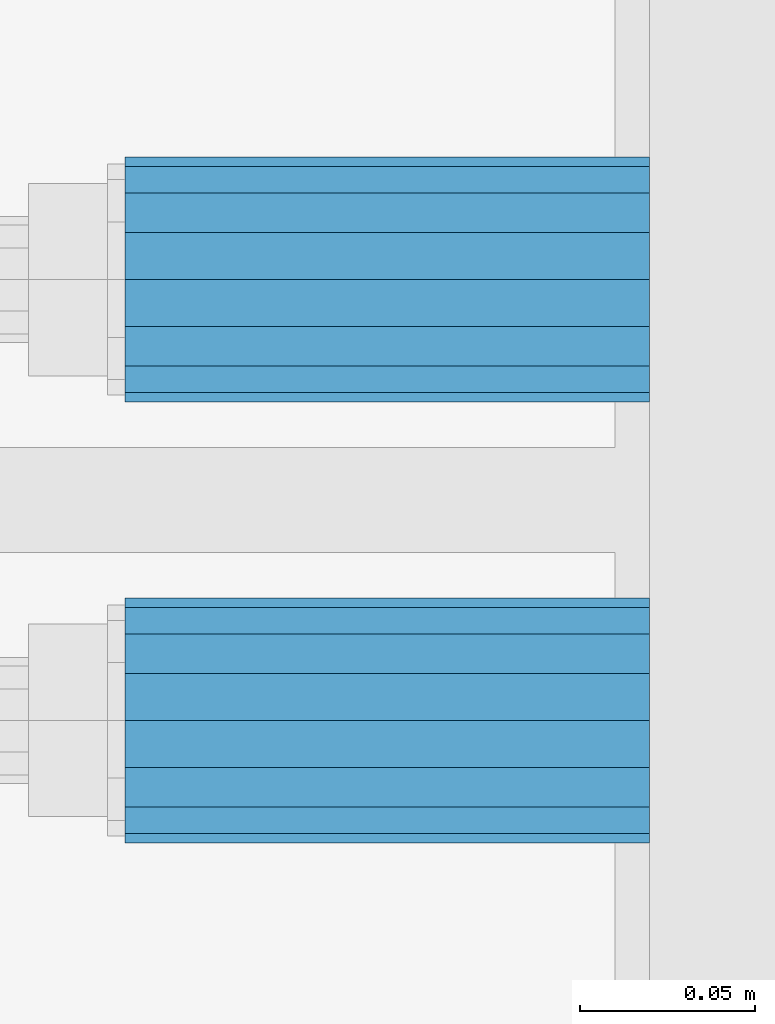
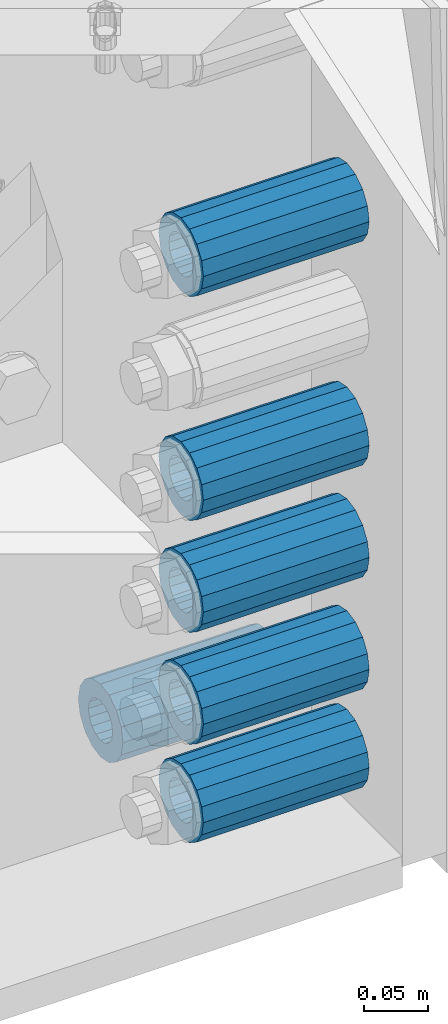
# One storey, part 142 of 240: 6 beams.
"""IFC2X3 building model written with IfcOpenShell, lengths in millimetres."""

from ifc_helpers import new_model, si_unit, frame, origin_with_axes, place, context, subcontext, project, spatial, faceted_brep, material, type_object, element, save


model = new_model("IFC2X3")

# Units and contexts
model_context = context("Model", 3, precision=1e-05, world=origin_with_axes())
body_context = subcontext(model_context, "Body", "Model", "MODEL_VIEW")
ifc_project = project(units=[si_unit("LENGTHUNIT", "METRE", prefix="MILLI"), si_unit("AREAUNIT", "SQUARE_METRE"), si_unit("VOLUMEUNIT", "CUBIC_METRE"), si_unit("MASSUNIT", "GRAM", prefix="KILO"), si_unit("TIMEUNIT", "SECOND"), si_unit("PLANEANGLEUNIT", "RADIAN"), si_unit("SOLIDANGLEUNIT", "STERADIAN"), si_unit("THERMODYNAMICTEMPERATUREUNIT", "DEGREE_CELSIUS"), si_unit("LUMINOUSINTENSITYUNIT", "LUMEN")], contexts=[model_context])

# Site, building, storey
site_placement = place(None, origin_with_axes())
site = spatial("IfcSite", under=ifc_project, at=site_placement, CompositionType="ELEMENT")
building_placement = place(site_placement, origin_with_axes())
building = spatial("IfcBuilding", under=site, at=building_placement, Name="Standard", CompositionType="ELEMENT")
storey_placement = place(building_placement, origin_with_axes())
storey = spatial("IfcBuildingStorey", under=building, at=storey_placement, Name="Undefined", CompositionType="ELEMENT", Elevation=0.0)

# Beams
ifc_material = material()
beam_type = type_object("IfcBeamType", PredefinedType="NOTDEFINED")
beam_1_placement = place(storey_placement, frame((56327.0, 29937.0, -285.0), z_axis=(0.0, 0.0, 1.0), x_axis=(1.0, 0.0, 0.0)))
element("IfcBeam", 1, at=beam_1_placement, inside=storey, type_object=beam_type, material=ifc_material, context=body_context, shape_type="Brep", body=[
    faceted_brep([(-1.31236447487026e-07, -18.9999999995492, -6.26459950581193e-09), (0.0, -17.5537111177146, 7.27098521493673), (150.0, -17.5537111177146, 7.27098521493673), (150.0, -19.0, 0.0), (0.0, -13.4350288425449, 13.4350288425444), (150.0, -13.4350288425449, 13.4350288425444), (0.0, -7.27098521493826, 17.5537111177144), (150.0, -7.27098521493826, 17.5537111177144), (-6.35918695479631e-09, 4.50199877377599e-10, 18.9999999937281), (150.0, 0.0, 19.0), (0.0, 7.27098521493826, 17.5537111177144), (150.0, 7.27098521493826, 17.5537111177144), (0.0, 13.4350288425449, 13.4350288425444), (150.0, 13.4350288425449, 13.4350288425444), (0.0, 17.5537111177146, 7.27098521493673), (150.0, 17.5537111177146, 7.27098521493673), (1.33248249767348e-07, 19.0000000004507, -6.26459950581193e-09), (150.0, 19.0, 0.0), (0.0, 17.5537111177146, -7.27098521493673), (150.0, 17.5537111177146, -7.27098521493673), (0.0, 13.4350288425449, -13.4350288425444), (150.0, 13.4350288425449, -13.4350288425444), (0.0, 7.27098521493826, -17.5537111177144), (150.0, 7.27098521493826, -17.5537111177144), (8.37098923511803e-09, 4.50313564215321e-10, -19.0000000062646), (150.0, 0.0, -19.0), (0.0, -7.27098521493826, -17.5537111177144), (150.0, -7.27098521493826, -17.5537111177144), (0.0, -13.4350288425449, -13.4350288425444), (150.0, -13.4350288425449, -13.4350288425444), (0.0, -17.5537111177146, -7.27098521493673), (150.0, -17.5537111177146, -7.27098521493673), (0.0, -35.0, 0.0), (7.27595761418343e-12, -32.335783637895, -13.3939201327739), (150.0, -32.3357836378964, -13.3939201327782), (150.0, -35.0, 0.0), (0.0, -24.7487373415292, -24.7487373415279), (150.0, -24.7487373415279, -24.7487373415292), (7.27595761418343e-12, -13.3939201327781, -32.3357836378891), (150.0, -13.3939201327776, -32.335783637895), (7.27595761418343e-12, 0.0, -35.0), (150.0, 0.0, -35.0), (7.27595761418343e-12, 13.3939201327782, -32.3357836378891), (150.0, 13.3939201327776, -32.335783637895), (0.0, 24.7487373415292, -24.7487373415279), (150.0, 24.7487373415279, -24.7487373415291), (7.27595761418343e-12, 32.335783637895, -13.3939201327739), (150.0, 32.3357836378964, -13.3939201327781), (0.0, 35.0, 0.0), (150.0, 35.0, 0.0), (0.0, 32.335783637895, 13.3939201327812), (150.0, 32.3357836378964, 13.3939201327781), (0.0, 24.7487373415292, 24.7487373415279), (150.0, 24.7487373415279, 24.7487373415292), (0.0, 13.3939201327781, 32.3357836378964), (150.0, 13.3939201327776, 32.335783637895), (0.0, 0.0, 35.0), (150.0, 0.0, 35.0), (0.0, -13.3939201327781, 32.3357836378964), (150.0, -13.3939201327776, 32.335783637895), (0.0, -24.7487373415292, 24.7487373415279), (150.0, -24.7487373415279, 24.7487373415292), (0.0, -32.335783637895, 13.3939201327812), (150.0, -32.3357836378964, 13.3939201327781)], [[[0, 1, 2, 3]], [[1, 4, 5, 2]], [[4, 6, 7, 5]], [[6, 8, 9, 7]], [[8, 10, 11, 9]], [[10, 12, 13, 11]], [[12, 14, 15, 13]], [[14, 16, 17, 15]], [[16, 18, 19, 17]], [[18, 20, 21, 19]], [[20, 22, 23, 21]], [[22, 24, 25, 23]], [[24, 26, 27, 25]], [[26, 28, 29, 27]], [[28, 30, 31, 29]], [[30, 0, 3, 31]], [[32, 33, 34, 35]], [[33, 36, 37, 34]], [[36, 38, 39, 37]], [[38, 40, 41, 39]], [[40, 42, 43, 41]], [[42, 44, 45, 43]], [[44, 46, 47, 45]], [[46, 48, 49, 47]], [[48, 50, 51, 49]], [[50, 52, 53, 51]], [[52, 54, 55, 53]], [[54, 56, 57, 55]], [[56, 58, 59, 57]], [[58, 60, 61, 59]], [[60, 62, 63, 61]], [[62, 32, 35, 63]], [[37, 39, 41, 43, 45, 47, 49, 51, 53, 55, 57, 59, 61, 63, 35, 34], [5, 7, 9, 11, 13, 15, 17, 19, 21, 23, 25, 27, 29, 31, 3, 2]], [[62, 60, 58, 56, 54, 52, 50, 48, 46, 44, 42, 40, 38, 36, 33, 32], [30, 28, 26, 24, 22, 20, 18, 16, 14, 12, 10, 8, 6, 4, 1, 0]]]),
])
beam_2_placement = place(storey_placement, frame((56327.0, 29937.0, -499.0), z_axis=(0.0, 0.0, 1.0), x_axis=(1.0, 0.0, 0.0)))
element("IfcBeam", 2, at=beam_2_placement, inside=storey, type_object=beam_type, material=ifc_material, context=body_context, shape_type="Brep", body=[
    faceted_brep([(-1.31236447487026e-07, -18.9999999995492, -6.26459950581193e-09), (0.0, -17.5537111177146, 7.27098521493673), (150.0, -17.5537111177146, 7.27098521493673), (150.0, -19.0, 0.0), (0.0, -13.4350288425449, 13.4350288425444), (150.0, -13.4350288425449, 13.4350288425444), (0.0, -7.27098521493826, 17.5537111177144), (150.0, -7.27098521493826, 17.5537111177144), (-6.35918695479631e-09, 4.50199877377599e-10, 18.9999999937281), (150.0, 0.0, 19.0), (0.0, 7.27098521493826, 17.5537111177144), (150.0, 7.27098521493826, 17.5537111177144), (0.0, 13.4350288425449, 13.4350288425444), (150.0, 13.4350288425449, 13.4350288425444), (0.0, 17.5537111177146, 7.27098521493673), (150.0, 17.5537111177146, 7.27098521493673), (1.33248249767348e-07, 19.0000000004507, -6.26459950581193e-09), (150.0, 19.0, 0.0), (0.0, 17.5537111177146, -7.27098521493673), (150.0, 17.5537111177146, -7.27098521493673), (0.0, 13.4350288425449, -13.4350288425444), (150.0, 13.4350288425449, -13.4350288425444), (0.0, 7.27098521493826, -17.5537111177144), (150.0, 7.27098521493826, -17.5537111177144), (8.37098923511803e-09, 4.50313564215321e-10, -19.0000000062646), (150.0, 0.0, -19.0), (0.0, -7.27098521493826, -17.5537111177144), (150.0, -7.27098521493826, -17.5537111177144), (0.0, -13.4350288425449, -13.4350288425444), (150.0, -13.4350288425449, -13.4350288425444), (0.0, -17.5537111177146, -7.27098521493673), (150.0, -17.5537111177146, -7.27098521493673), (0.0, -35.0, 0.0), (7.27595761418343e-12, -32.335783637895, -13.3939201327739), (150.0, -32.3357836378964, -13.3939201327782), (150.0, -35.0, 0.0), (0.0, -24.7487373415292, -24.7487373415279), (150.0, -24.7487373415279, -24.7487373415292), (7.27595761418343e-12, -13.3939201327781, -32.3357836378891), (150.0, -13.3939201327776, -32.335783637895), (7.27595761418343e-12, 0.0, -35.0), (150.0, 0.0, -35.0), (7.27595761418343e-12, 13.3939201327782, -32.3357836378891), (150.0, 13.3939201327776, -32.335783637895), (0.0, 24.7487373415292, -24.7487373415279), (150.0, 24.7487373415279, -24.7487373415291), (7.27595761418343e-12, 32.335783637895, -13.3939201327739), (150.0, 32.3357836378964, -13.3939201327781), (0.0, 35.0, 0.0), (150.0, 35.0, 0.0), (0.0, 32.335783637895, 13.3939201327812), (150.0, 32.3357836378964, 13.3939201327781), (0.0, 24.7487373415292, 24.7487373415279), (150.0, 24.7487373415279, 24.7487373415292), (0.0, 13.3939201327781, 32.3357836378964), (150.0, 13.3939201327776, 32.335783637895), (0.0, 0.0, 35.0), (150.0, 0.0, 35.0), (0.0, -13.3939201327781, 32.3357836378964), (150.0, -13.3939201327776, 32.335783637895), (0.0, -24.7487373415292, 24.7487373415279), (150.0, -24.7487373415279, 24.7487373415292), (0.0, -32.335783637895, 13.3939201327812), (150.0, -32.3357836378964, 13.3939201327781)], [[[0, 1, 2, 3]], [[1, 4, 5, 2]], [[4, 6, 7, 5]], [[6, 8, 9, 7]], [[8, 10, 11, 9]], [[10, 12, 13, 11]], [[12, 14, 15, 13]], [[14, 16, 17, 15]], [[16, 18, 19, 17]], [[18, 20, 21, 19]], [[20, 22, 23, 21]], [[22, 24, 25, 23]], [[24, 26, 27, 25]], [[26, 28, 29, 27]], [[28, 30, 31, 29]], [[30, 0, 3, 31]], [[32, 33, 34, 35]], [[33, 36, 37, 34]], [[36, 38, 39, 37]], [[38, 40, 41, 39]], [[40, 42, 43, 41]], [[42, 44, 45, 43]], [[44, 46, 47, 45]], [[46, 48, 49, 47]], [[48, 50, 51, 49]], [[50, 52, 53, 51]], [[52, 54, 55, 53]], [[54, 56, 57, 55]], [[56, 58, 59, 57]], [[58, 60, 61, 59]], [[60, 62, 63, 61]], [[62, 32, 35, 63]], [[37, 39, 41, 43, 45, 47, 49, 51, 53, 55, 57, 59, 61, 63, 35, 34], [5, 7, 9, 11, 13, 15, 17, 19, 21, 23, 25, 27, 29, 31, 3, 2]], [[62, 60, 58, 56, 54, 52, 50, 48, 46, 44, 42, 40, 38, 36, 33, 32], [30, 28, 26, 24, 22, 20, 18, 16, 14, 12, 10, 8, 6, 4, 1, 0]]]),
])
beam_3_placement = place(storey_placement, frame((56327.0, 29937.0, -606.0), z_axis=(0.0, 0.0, 1.0), x_axis=(1.0, 0.0, 0.0)))
element("IfcBeam", 3, at=beam_3_placement, inside=storey, type_object=beam_type, material=ifc_material, context=body_context, shape_type="Brep", body=[
    faceted_brep([(-1.31236447487026e-07, -18.9999999995492, -6.26459950581193e-09), (0.0, -17.5537111177146, 7.27098521493673), (150.0, -17.5537111177146, 7.27098521493673), (150.0, -19.0, 0.0), (0.0, -13.4350288425449, 13.4350288425444), (150.0, -13.4350288425449, 13.4350288425444), (0.0, -7.27098521493826, 17.5537111177144), (150.0, -7.27098521493826, 17.5537111177144), (-6.35918695479631e-09, 4.50199877377599e-10, 18.9999999937281), (150.0, 0.0, 19.0), (0.0, 7.27098521493826, 17.5537111177144), (150.0, 7.27098521493826, 17.5537111177144), (0.0, 13.4350288425449, 13.4350288425444), (150.0, 13.4350288425449, 13.4350288425444), (0.0, 17.5537111177146, 7.27098521493673), (150.0, 17.5537111177146, 7.27098521493673), (1.33248249767348e-07, 19.0000000004507, -6.26459950581193e-09), (150.0, 19.0, 0.0), (0.0, 17.5537111177146, -7.27098521493673), (150.0, 17.5537111177146, -7.27098521493673), (0.0, 13.4350288425449, -13.4350288425444), (150.0, 13.4350288425449, -13.4350288425444), (0.0, 7.27098521493826, -17.5537111177144), (150.0, 7.27098521493826, -17.5537111177144), (8.37098923511803e-09, 4.50313564215321e-10, -19.0000000062646), (150.0, 0.0, -19.0), (0.0, -7.27098521493826, -17.5537111177144), (150.0, -7.27098521493826, -17.5537111177144), (0.0, -13.4350288425449, -13.4350288425444), (150.0, -13.4350288425449, -13.4350288425444), (0.0, -17.5537111177146, -7.27098521493673), (150.0, -17.5537111177146, -7.27098521493673), (0.0, -35.0, 0.0), (7.27595761418343e-12, -32.335783637895, -13.3939201327739), (150.0, -32.3357836378964, -13.3939201327782), (150.0, -35.0, 0.0), (0.0, -24.7487373415292, -24.7487373415279), (150.0, -24.7487373415279, -24.7487373415292), (7.27595761418343e-12, -13.3939201327781, -32.3357836378891), (150.0, -13.3939201327776, -32.335783637895), (7.27595761418343e-12, 0.0, -35.0), (150.0, 0.0, -35.0), (7.27595761418343e-12, 13.3939201327782, -32.3357836378891), (150.0, 13.3939201327776, -32.335783637895), (0.0, 24.7487373415292, -24.7487373415279), (150.0, 24.7487373415279, -24.7487373415291), (7.27595761418343e-12, 32.335783637895, -13.3939201327739), (150.0, 32.3357836378964, -13.3939201327781), (0.0, 35.0, 0.0), (150.0, 35.0, 0.0), (0.0, 32.335783637895, 13.3939201327812), (150.0, 32.3357836378964, 13.3939201327781), (0.0, 24.7487373415292, 24.7487373415279), (150.0, 24.7487373415279, 24.7487373415292), (0.0, 13.3939201327781, 32.3357836378964), (150.0, 13.3939201327776, 32.335783637895), (0.0, 0.0, 35.0), (150.0, 0.0, 35.0), (0.0, -13.3939201327781, 32.3357836378964), (150.0, -13.3939201327776, 32.335783637895), (0.0, -24.7487373415292, 24.7487373415279), (150.0, -24.7487373415279, 24.7487373415292), (0.0, -32.335783637895, 13.3939201327812), (150.0, -32.3357836378964, 13.3939201327781)], [[[0, 1, 2, 3]], [[1, 4, 5, 2]], [[4, 6, 7, 5]], [[6, 8, 9, 7]], [[8, 10, 11, 9]], [[10, 12, 13, 11]], [[12, 14, 15, 13]], [[14, 16, 17, 15]], [[16, 18, 19, 17]], [[18, 20, 21, 19]], [[20, 22, 23, 21]], [[22, 24, 25, 23]], [[24, 26, 27, 25]], [[26, 28, 29, 27]], [[28, 30, 31, 29]], [[30, 0, 3, 31]], [[32, 33, 34, 35]], [[33, 36, 37, 34]], [[36, 38, 39, 37]], [[38, 40, 41, 39]], [[40, 42, 43, 41]], [[42, 44, 45, 43]], [[44, 46, 47, 45]], [[46, 48, 49, 47]], [[48, 50, 51, 49]], [[50, 52, 53, 51]], [[52, 54, 55, 53]], [[54, 56, 57, 55]], [[56, 58, 59, 57]], [[58, 60, 61, 59]], [[60, 62, 63, 61]], [[62, 32, 35, 63]], [[37, 39, 41, 43, 45, 47, 49, 51, 53, 55, 57, 59, 61, 63, 35, 34], [5, 7, 9, 11, 13, 15, 17, 19, 21, 23, 25, 27, 29, 31, 3, 2]], [[62, 60, 58, 56, 54, 52, 50, 48, 46, 44, 42, 40, 38, 36, 33, 32], [30, 28, 26, 24, 22, 20, 18, 16, 14, 12, 10, 8, 6, 4, 1, 0]]]),
])
beam_4_placement = place(storey_placement, frame((56327.0, 29937.0, -713.0), z_axis=(0.0, 0.0, 1.0), x_axis=(1.0, 0.0, 0.0)))
element("IfcBeam", 4, at=beam_4_placement, inside=storey, type_object=beam_type, material=ifc_material, context=body_context, shape_type="Brep", body=[
    faceted_brep([(-1.31236447487026e-07, -18.9999999995492, -6.26459950581193e-09), (0.0, -17.5537111177146, 7.27098521493673), (150.0, -17.5537111177146, 7.27098521493673), (150.0, -19.0, 0.0), (0.0, -13.4350288425449, 13.4350288425444), (150.0, -13.4350288425449, 13.4350288425444), (0.0, -7.27098521493826, 17.5537111177144), (150.0, -7.27098521493826, 17.5537111177144), (-6.35918695479631e-09, 4.50199877377599e-10, 18.9999999937281), (150.0, 0.0, 19.0), (0.0, 7.27098521493826, 17.5537111177144), (150.0, 7.27098521493826, 17.5537111177144), (0.0, 13.4350288425449, 13.4350288425444), (150.0, 13.4350288425449, 13.4350288425444), (0.0, 17.5537111177146, 7.27098521493673), (150.0, 17.5537111177146, 7.27098521493673), (1.33248249767348e-07, 19.0000000004507, -6.26459950581193e-09), (150.0, 19.0, 0.0), (0.0, 17.5537111177146, -7.27098521493673), (150.0, 17.5537111177146, -7.27098521493673), (0.0, 13.4350288425449, -13.4350288425444), (150.0, 13.4350288425449, -13.4350288425444), (0.0, 7.27098521493826, -17.5537111177144), (150.0, 7.27098521493826, -17.5537111177144), (8.37098923511803e-09, 4.50313564215321e-10, -19.0000000062646), (150.0, 0.0, -19.0), (0.0, -7.27098521493826, -17.5537111177144), (150.0, -7.27098521493826, -17.5537111177144), (0.0, -13.4350288425449, -13.4350288425444), (150.0, -13.4350288425449, -13.4350288425444), (0.0, -17.5537111177146, -7.27098521493673), (150.0, -17.5537111177146, -7.27098521493673), (0.0, -35.0, 0.0), (7.27595761418343e-12, -32.335783637895, -13.3939201327739), (150.0, -32.3357836378964, -13.3939201327782), (150.0, -35.0, 0.0), (0.0, -24.7487373415292, -24.7487373415279), (150.0, -24.7487373415279, -24.7487373415292), (7.27595761418343e-12, -13.3939201327781, -32.3357836378891), (150.0, -13.3939201327776, -32.335783637895), (7.27595761418343e-12, 0.0, -35.0), (150.0, 0.0, -35.0), (7.27595761418343e-12, 13.3939201327782, -32.3357836378891), (150.0, 13.3939201327776, -32.335783637895), (0.0, 24.7487373415292, -24.7487373415279), (150.0, 24.7487373415279, -24.7487373415291), (7.27595761418343e-12, 32.335783637895, -13.3939201327739), (150.0, 32.3357836378964, -13.3939201327781), (0.0, 35.0, 0.0), (150.0, 35.0, 0.0), (0.0, 32.335783637895, 13.3939201327812), (150.0, 32.3357836378964, 13.3939201327781), (0.0, 24.7487373415292, 24.7487373415279), (150.0, 24.7487373415279, 24.7487373415292), (0.0, 13.3939201327781, 32.3357836378964), (150.0, 13.3939201327776, 32.335783637895), (0.0, 0.0, 35.0), (150.0, 0.0, 35.0), (0.0, -13.3939201327781, 32.3357836378964), (150.0, -13.3939201327776, 32.335783637895), (0.0, -24.7487373415292, 24.7487373415279), (150.0, -24.7487373415279, 24.7487373415292), (0.0, -32.335783637895, 13.3939201327812), (150.0, -32.3357836378964, 13.3939201327781)], [[[0, 1, 2, 3]], [[1, 4, 5, 2]], [[4, 6, 7, 5]], [[6, 8, 9, 7]], [[8, 10, 11, 9]], [[10, 12, 13, 11]], [[12, 14, 15, 13]], [[14, 16, 17, 15]], [[16, 18, 19, 17]], [[18, 20, 21, 19]], [[20, 22, 23, 21]], [[22, 24, 25, 23]], [[24, 26, 27, 25]], [[26, 28, 29, 27]], [[28, 30, 31, 29]], [[30, 0, 3, 31]], [[32, 33, 34, 35]], [[33, 36, 37, 34]], [[36, 38, 39, 37]], [[38, 40, 41, 39]], [[40, 42, 43, 41]], [[42, 44, 45, 43]], [[44, 46, 47, 45]], [[46, 48, 49, 47]], [[48, 50, 51, 49]], [[50, 52, 53, 51]], [[52, 54, 55, 53]], [[54, 56, 57, 55]], [[56, 58, 59, 57]], [[58, 60, 61, 59]], [[60, 62, 63, 61]], [[62, 32, 35, 63]], [[37, 39, 41, 43, 45, 47, 49, 51, 53, 55, 57, 59, 61, 63, 35, 34], [5, 7, 9, 11, 13, 15, 17, 19, 21, 23, 25, 27, 29, 31, 3, 2]], [[62, 60, 58, 56, 54, 52, 50, 48, 46, 44, 42, 40, 38, 36, 33, 32], [30, 28, 26, 24, 22, 20, 18, 16, 14, 12, 10, 8, 6, 4, 1, 0]]]),
])
beam_5_placement = place(storey_placement, frame((56327.0, 30063.0, -807.0), z_axis=(0.0, 0.0, 1.0), x_axis=(1.0, 0.0, 0.0)))
element("IfcBeam", 5, at=beam_5_placement, inside=storey, type_object=beam_type, material=ifc_material, context=body_context, shape_type="Brep", body=[
    faceted_brep([(-1.31236447487026e-07, -18.9999999995492, -6.26459950581193e-09), (0.0, -17.5537111177146, 7.27098521493673), (150.0, -17.5537111177146, 7.27098521493673), (150.0, -19.0, 0.0), (0.0, -13.4350288425449, 13.4350288425444), (150.0, -13.4350288425449, 13.4350288425444), (0.0, -7.27098521493826, 17.5537111177144), (150.0, -7.27098521493826, 17.5537111177144), (-6.35918695479631e-09, 4.50199877377599e-10, 18.9999999937281), (150.0, 0.0, 19.0), (0.0, 7.27098521493826, 17.5537111177144), (150.0, 7.27098521493826, 17.5537111177144), (0.0, 13.4350288425449, 13.4350288425444), (150.0, 13.4350288425449, 13.4350288425444), (0.0, 17.5537111177146, 7.27098521493673), (150.0, 17.5537111177146, 7.27098521493673), (1.33248249767348e-07, 19.0000000004507, -6.26459950581193e-09), (150.0, 19.0, 0.0), (0.0, 17.5537111177146, -7.27098521493673), (150.0, 17.5537111177146, -7.27098521493673), (0.0, 13.4350288425449, -13.4350288425444), (150.0, 13.4350288425449, -13.4350288425444), (0.0, 7.27098521493826, -17.5537111177144), (150.0, 7.27098521493826, -17.5537111177144), (8.37098923511803e-09, 4.50313564215321e-10, -19.0000000062646), (150.0, 0.0, -19.0), (0.0, -7.27098521493826, -17.5537111177144), (150.0, -7.27098521493826, -17.5537111177144), (0.0, -13.4350288425449, -13.4350288425444), (150.0, -13.4350288425449, -13.4350288425444), (0.0, -17.5537111177146, -7.27098521493673), (150.0, -17.5537111177146, -7.27098521493673), (0.0, -35.0, 0.0), (7.27595761418343e-12, -32.335783637895, -13.3939201327739), (150.0, -32.3357836378964, -13.3939201327782), (150.0, -35.0, 0.0), (0.0, -24.7487373415292, -24.7487373415279), (150.0, -24.7487373415279, -24.7487373415292), (7.27595761418343e-12, -13.3939201327781, -32.3357836378891), (150.0, -13.3939201327776, -32.335783637895), (7.27595761418343e-12, 0.0, -35.0), (150.0, 0.0, -35.0), (7.27595761418343e-12, 13.3939201327782, -32.3357836378891), (150.0, 13.3939201327776, -32.335783637895), (0.0, 24.7487373415292, -24.7487373415279), (150.0, 24.7487373415279, -24.7487373415291), (7.27595761418343e-12, 32.335783637895, -13.3939201327739), (150.0, 32.3357836378964, -13.3939201327781), (0.0, 35.0, 0.0), (150.0, 35.0, 0.0), (0.0, 32.335783637895, 13.3939201327812), (150.0, 32.3357836378964, 13.3939201327781), (0.0, 24.7487373415292, 24.7487373415279), (150.0, 24.7487373415279, 24.7487373415292), (0.0, 13.3939201327781, 32.3357836378964), (150.0, 13.3939201327776, 32.335783637895), (0.0, 0.0, 35.0), (150.0, 0.0, 35.0), (0.0, -13.3939201327781, 32.3357836378964), (150.0, -13.3939201327776, 32.335783637895), (0.0, -24.7487373415292, 24.7487373415279), (150.0, -24.7487373415279, 24.7487373415292), (0.0, -32.335783637895, 13.3939201327812), (150.0, -32.3357836378964, 13.3939201327781)], [[[0, 1, 2, 3]], [[1, 4, 5, 2]], [[4, 6, 7, 5]], [[6, 8, 9, 7]], [[8, 10, 11, 9]], [[10, 12, 13, 11]], [[12, 14, 15, 13]], [[14, 16, 17, 15]], [[16, 18, 19, 17]], [[18, 20, 21, 19]], [[20, 22, 23, 21]], [[22, 24, 25, 23]], [[24, 26, 27, 25]], [[26, 28, 29, 27]], [[28, 30, 31, 29]], [[30, 0, 3, 31]], [[32, 33, 34, 35]], [[33, 36, 37, 34]], [[36, 38, 39, 37]], [[38, 40, 41, 39]], [[40, 42, 43, 41]], [[42, 44, 45, 43]], [[44, 46, 47, 45]], [[46, 48, 49, 47]], [[48, 50, 51, 49]], [[50, 52, 53, 51]], [[52, 54, 55, 53]], [[54, 56, 57, 55]], [[56, 58, 59, 57]], [[58, 60, 61, 59]], [[60, 62, 63, 61]], [[62, 32, 35, 63]], [[37, 39, 41, 43, 45, 47, 49, 51, 53, 55, 57, 59, 61, 63, 35, 34], [5, 7, 9, 11, 13, 15, 17, 19, 21, 23, 25, 27, 29, 31, 3, 2]], [[62, 60, 58, 56, 54, 52, 50, 48, 46, 44, 42, 40, 38, 36, 33, 32], [30, 28, 26, 24, 22, 20, 18, 16, 14, 12, 10, 8, 6, 4, 1, 0]]]),
])
beam_6_placement = place(storey_placement, frame((56327.0, 29937.0, -807.0), z_axis=(0.0, 0.0, 1.0), x_axis=(1.0, 0.0, 0.0)))
element("IfcBeam", 6, at=beam_6_placement, inside=storey, type_object=beam_type, material=ifc_material, context=body_context, shape_type="Brep", body=[
    faceted_brep([(-1.31236447487026e-07, -18.9999999995492, -6.26459950581193e-09), (0.0, -17.5537111177146, 7.27098521493673), (150.0, -17.5537111177146, 7.27098521493673), (150.0, -19.0, 0.0), (0.0, -13.4350288425449, 13.4350288425444), (150.0, -13.4350288425449, 13.4350288425444), (0.0, -7.27098521493826, 17.5537111177144), (150.0, -7.27098521493826, 17.5537111177144), (-6.35918695479631e-09, 4.50199877377599e-10, 18.9999999937281), (150.0, 0.0, 19.0), (0.0, 7.27098521493826, 17.5537111177144), (150.0, 7.27098521493826, 17.5537111177144), (0.0, 13.4350288425449, 13.4350288425444), (150.0, 13.4350288425449, 13.4350288425444), (0.0, 17.5537111177146, 7.27098521493673), (150.0, 17.5537111177146, 7.27098521493673), (1.33248249767348e-07, 19.0000000004507, -6.26459950581193e-09), (150.0, 19.0, 0.0), (0.0, 17.5537111177146, -7.27098521493673), (150.0, 17.5537111177146, -7.27098521493673), (0.0, 13.4350288425449, -13.4350288425444), (150.0, 13.4350288425449, -13.4350288425444), (0.0, 7.27098521493826, -17.5537111177144), (150.0, 7.27098521493826, -17.5537111177144), (8.37098923511803e-09, 4.50313564215321e-10, -19.0000000062646), (150.0, 0.0, -19.0), (0.0, -7.27098521493826, -17.5537111177144), (150.0, -7.27098521493826, -17.5537111177144), (0.0, -13.4350288425449, -13.4350288425444), (150.0, -13.4350288425449, -13.4350288425444), (0.0, -17.5537111177146, -7.27098521493673), (150.0, -17.5537111177146, -7.27098521493673), (0.0, -35.0, 0.0), (7.27595761418343e-12, -32.335783637895, -13.3939201327739), (150.0, -32.3357836378964, -13.3939201327782), (150.0, -35.0, 0.0), (0.0, -24.7487373415292, -24.7487373415279), (150.0, -24.7487373415279, -24.7487373415292), (7.27595761418343e-12, -13.3939201327781, -32.3357836378891), (150.0, -13.3939201327776, -32.335783637895), (7.27595761418343e-12, 0.0, -35.0), (150.0, 0.0, -35.0), (7.27595761418343e-12, 13.3939201327782, -32.3357836378891), (150.0, 13.3939201327776, -32.335783637895), (0.0, 24.7487373415292, -24.7487373415279), (150.0, 24.7487373415279, -24.7487373415291), (7.27595761418343e-12, 32.335783637895, -13.3939201327739), (150.0, 32.3357836378964, -13.3939201327781), (0.0, 35.0, 0.0), (150.0, 35.0, 0.0), (0.0, 32.335783637895, 13.3939201327812), (150.0, 32.3357836378964, 13.3939201327781), (0.0, 24.7487373415292, 24.7487373415279), (150.0, 24.7487373415279, 24.7487373415292), (0.0, 13.3939201327781, 32.3357836378964), (150.0, 13.3939201327776, 32.335783637895), (0.0, 0.0, 35.0), (150.0, 0.0, 35.0), (0.0, -13.3939201327781, 32.3357836378964), (150.0, -13.3939201327776, 32.335783637895), (0.0, -24.7487373415292, 24.7487373415279), (150.0, -24.7487373415279, 24.7487373415292), (0.0, -32.335783637895, 13.3939201327812), (150.0, -32.3357836378964, 13.3939201327781)], [[[0, 1, 2, 3]], [[1, 4, 5, 2]], [[4, 6, 7, 5]], [[6, 8, 9, 7]], [[8, 10, 11, 9]], [[10, 12, 13, 11]], [[12, 14, 15, 13]], [[14, 16, 17, 15]], [[16, 18, 19, 17]], [[18, 20, 21, 19]], [[20, 22, 23, 21]], [[22, 24, 25, 23]], [[24, 26, 27, 25]], [[26, 28, 29, 27]], [[28, 30, 31, 29]], [[30, 0, 3, 31]], [[32, 33, 34, 35]], [[33, 36, 37, 34]], [[36, 38, 39, 37]], [[38, 40, 41, 39]], [[40, 42, 43, 41]], [[42, 44, 45, 43]], [[44, 46, 47, 45]], [[46, 48, 49, 47]], [[48, 50, 51, 49]], [[50, 52, 53, 51]], [[52, 54, 55, 53]], [[54, 56, 57, 55]], [[56, 58, 59, 57]], [[58, 60, 61, 59]], [[60, 62, 63, 61]], [[62, 32, 35, 63]], [[37, 39, 41, 43, 45, 47, 49, 51, 53, 55, 57, 59, 61, 63, 35, 34], [5, 7, 9, 11, 13, 15, 17, 19, 21, 23, 25, 27, 29, 31, 3, 2]], [[62, 60, 58, 56, 54, 52, 50, 48, 46, 44, 42, 40, 38, 36, 33, 32], [30, 28, 26, 24, 22, 20, 18, 16, 14, 12, 10, 8, 6, 4, 1, 0]]]),
])

save(model, "model.ifc")
